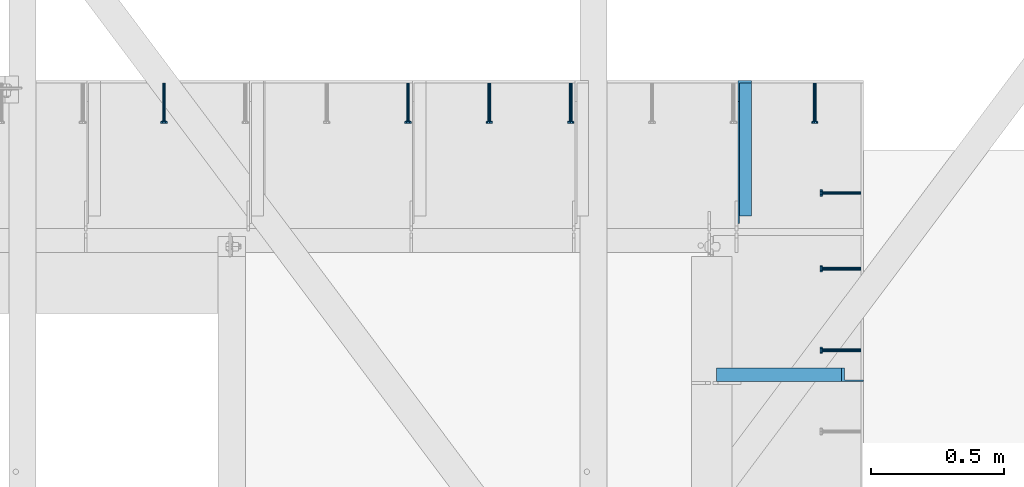
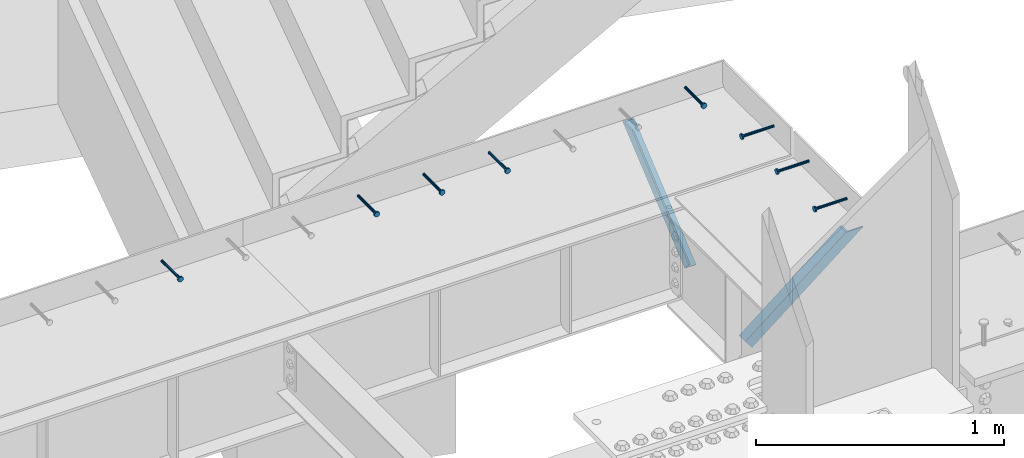
# One storey, part 1363 of 1763: 8 beams, 2 members, 10 elements without a shape of their own.
"""IFC2X3 building model written with IfcOpenShell, lengths in millimetres."""

from ifc_helpers import new_model, si_unit, frame, origin_with_axes, place, context, subcontext, project, spatial, faceted_brep, material, type_object, element, aggregate, save


model = new_model("IFC2X3")

# Units and contexts
model_context = context("Model", 3, precision=1e-05, world=origin_with_axes())
body_context = subcontext(model_context, "Body", "Model", "MODEL_VIEW")
ifc_project = project(units=[si_unit("LENGTHUNIT", "METRE", prefix="MILLI"), si_unit("AREAUNIT", "SQUARE_METRE"), si_unit("VOLUMEUNIT", "CUBIC_METRE"), si_unit("MASSUNIT", "GRAM", prefix="KILO"), si_unit("TIMEUNIT", "SECOND"), si_unit("PLANEANGLEUNIT", "RADIAN"), si_unit("SOLIDANGLEUNIT", "STERADIAN"), si_unit("THERMODYNAMICTEMPERATUREUNIT", "DEGREE_CELSIUS"), si_unit("LUMINOUSINTENSITYUNIT", "LUMEN")], contexts=[model_context])

# Site, building, storey
site_placement = place(None, origin_with_axes())
site = spatial("IfcSite", under=ifc_project, at=site_placement, CompositionType="ELEMENT")
building_placement = place(site_placement, origin_with_axes())
building = spatial("IfcBuilding", under=site, at=building_placement, Name="Undefined", CompositionType="ELEMENT")
storey_placement = place(building_placement, origin_with_axes())
storey = spatial("IfcBuildingStorey", under=building, at=storey_placement, Name="Undefined", CompositionType="ELEMENT", Elevation=0.0)

# Assembly, beam
assembly_1_placement = place(storey_placement, origin_with_axes())
assembly_1 = element("IfcElementAssembly", 1, at=assembly_1_placement, inside=storey, Name="HEADED STUD ANCHOR", AssemblyPlace="NOTDEFINED", PredefinedType="RIGID_FRAME")
ifc_material_1 = material(Name="STEEL/A108")
beam_type = type_object("IfcBeamType", PredefinedType="NOTDEFINED")
beam_1_placement = place(assembly_1_placement, frame((-34391.0368708663, 53201.8884999161, 5264.15), z_axis=(0.0, 0.0, 1.0), x_axis=(-1.0, 0.0, 0.0)))
beam_1 = element("IfcBeam", 2, at=beam_1_placement, type_object=beam_type, material=ifc_material_1, Name="HEADED STUD ANCHOR", context=body_context, shape_type="Brep", body=[
    faceted_brep([(0.0, -3.1800000667572, 5.5), (0.0, -5.5, 3.1800000667572), (141.732000000002, -5.5, 3.1800000667572), (141.732000000002, -3.1800000667572, 5.5), (0.0, -6.34999999999491, 1.45519152283669e-11), (141.732000000002, -6.34999990463257, 0.0), (0.0, -5.5, -3.1800000667572), (141.732000000002, -5.5, -3.1800000667572), (0.0, -3.1800000667572, -5.5), (141.732000000002, -3.1800000667572, -5.5), (0.0, 0.0, -6.34999990463257), (141.732000000002, 0.0, -6.34999990463257), (0.0, 3.1800000667572, -5.5), (141.732000000002, 3.1800000667572, -5.5), (0.0, 5.5, -3.1800000667572), (141.732000000002, 5.5, -3.1800000667572), (0.0, 6.34999999999491, -2.91038304567337e-11), (141.732000000002, 6.34999990463257, 0.0), (0.0, 5.5, 3.1800000667572), (141.732000000002, 5.5, 3.1800000667572), (0.0, 3.1800000667572, 5.5), (141.732000000002, 3.1800000667572, 5.5), (0.0, 0.0, 6.34999990463257), (141.732000000002, 0.0, 6.34999990463257), (144.780000000001, -10.9899997711182, 6.34999990463257), (144.780000000001, -6.34000015258789, 10.9899997711182), (144.780000000001, -12.6999998092651, 0.0), (144.780000000001, -10.9899997711182, -6.34999990463257), (144.780000000001, -6.34000015258789, -10.9899997711182), (144.780000000001, 0.0, -12.6899995803833), (144.780000000001, 6.34000015258789, -10.9899997711182), (144.780000000001, 10.9899997711182, -6.34999990463257), (144.780000000001, 12.6999998092651, 0.0), (144.780000000001, 10.9899997711182, 6.34999990463257), (144.780000000001, 6.34000015258789, 10.9899997711182), (144.780000000001, 0.0, 12.6899995803833), (152.400000000001, -10.9899997711182, 6.34999990463257), (152.400000000001, -6.34000015258789, 10.9899997711182), (152.400000000001, -12.6999998092651, 0.0), (152.400000000001, -10.9899997711182, -6.34999990463257), (152.400000000001, -6.34000015258789, -10.9899997711182), (152.400000000001, 0.0, -12.6899995803833), (152.400000000001, 6.34000015258789, -10.9899997711182), (152.400000000001, 10.9899997711182, -6.34999990463257), (152.400000000001, 12.6999998092651, 0.0), (152.400000000001, 10.9899997711182, 6.34999990463257), (152.400000000001, 6.34000015258789, 10.9899997711182), (152.400000000001, 0.0, 12.6899995803833)], [[[0, 1, 2, 3]], [[1, 4, 5, 2]], [[4, 6, 7, 5]], [[6, 8, 9, 7]], [[8, 10, 11, 9]], [[10, 12, 13, 11]], [[12, 14, 15, 13]], [[14, 16, 17, 15]], [[16, 18, 19, 17]], [[18, 20, 21, 19]], [[20, 22, 23, 21]], [[22, 0, 3, 23]], [[22, 20, 18, 16, 14, 12, 10, 8, 6, 4, 1, 0]], [[3, 2, 24, 25]], [[2, 5, 26, 24]], [[5, 7, 27, 26]], [[7, 9, 28, 27]], [[9, 11, 29, 28]], [[11, 13, 30, 29]], [[13, 15, 31, 30]], [[15, 17, 32, 31]], [[17, 19, 33, 32]], [[19, 21, 34, 33]], [[21, 23, 35, 34]], [[23, 3, 25, 35]], [[25, 24, 36, 37]], [[24, 26, 38, 36]], [[26, 27, 39, 38]], [[27, 28, 40, 39]], [[28, 29, 41, 40]], [[29, 30, 42, 41]], [[30, 31, 43, 42]], [[31, 32, 44, 43]], [[32, 33, 45, 44]], [[33, 34, 46, 45]], [[34, 35, 47, 46]], [[35, 25, 37, 47]], [[38, 39, 40, 41, 42, 43, 44, 45, 46, 47, 37, 36]]]),
])
aggregate(assembly_1, [beam_1])

assembly_2_placement = place(storey_placement, origin_with_axes())
assembly_2 = element("IfcElementAssembly", 3, at=assembly_2_placement, inside=storey, Name="HEADED STUD ANCHOR", AssemblyPlace="NOTDEFINED", PredefinedType="RIGID_FRAME")
beam_2_placement = place(assembly_2_placement, frame((-34391.0368708663, 53506.6884999161, 5264.15), z_axis=(0.0, 0.0, 1.0), x_axis=(-1.0, 0.0, 0.0)))
beam_2 = element("IfcBeam", 4, at=beam_2_placement, type_object=beam_type, material=ifc_material_1, Name="HEADED STUD ANCHOR", context=body_context, shape_type="Brep", body=[
    faceted_brep([(0.0, -3.1800000667572, 5.5), (0.0, -5.5, 3.1800000667572), (141.732000000002, -5.5, 3.1800000667572), (141.732000000002, -3.1800000667572, 5.5), (0.0, -6.34999999999491, 1.45519152283669e-11), (141.732000000002, -6.34999990463257, 0.0), (0.0, -5.5, -3.1800000667572), (141.732000000002, -5.5, -3.1800000667572), (0.0, -3.1800000667572, -5.5), (141.732000000002, -3.1800000667572, -5.5), (0.0, 0.0, -6.34999990463257), (141.732000000002, 0.0, -6.34999990463257), (0.0, 3.1800000667572, -5.5), (141.732000000002, 3.1800000667572, -5.5), (0.0, 5.5, -3.1800000667572), (141.732000000002, 5.5, -3.1800000667572), (0.0, 6.34999999999491, -2.91038304567337e-11), (141.732000000002, 6.34999990463257, 0.0), (0.0, 5.5, 3.1800000667572), (141.732000000002, 5.5, 3.1800000667572), (0.0, 3.1800000667572, 5.5), (141.732000000002, 3.1800000667572, 5.5), (0.0, 0.0, 6.34999990463257), (141.732000000002, 0.0, 6.34999990463257), (144.780000000001, -10.9899997711182, 6.34999990463257), (144.780000000001, -6.34000015258789, 10.9899997711182), (144.780000000001, -12.6999998092651, 0.0), (144.780000000001, -10.9899997711182, -6.34999990463257), (144.780000000001, -6.34000015258789, -10.9899997711182), (144.780000000001, 0.0, -12.6899995803833), (144.780000000001, 6.34000015258789, -10.9899997711182), (144.780000000001, 10.9899997711182, -6.34999990463257), (144.780000000001, 12.6999998092651, 0.0), (144.780000000001, 10.9899997711182, 6.34999990463257), (144.780000000001, 6.34000015258789, 10.9899997711182), (144.780000000001, 0.0, 12.6899995803833), (152.400000000001, -10.9899997711182, 6.34999990463257), (152.400000000001, -6.34000015258789, 10.9899997711182), (152.400000000001, -12.6999998092651, 0.0), (152.400000000001, -10.9899997711182, -6.34999990463257), (152.400000000001, -6.34000015258789, -10.9899997711182), (152.400000000001, 0.0, -12.6899995803833), (152.400000000001, 6.34000015258789, -10.9899997711182), (152.400000000001, 10.9899997711182, -6.34999990463257), (152.400000000001, 12.6999998092651, 0.0), (152.400000000001, 10.9899997711182, 6.34999990463257), (152.400000000001, 6.34000015258789, 10.9899997711182), (152.400000000001, 0.0, 12.6899995803833)], [[[0, 1, 2, 3]], [[1, 4, 5, 2]], [[4, 6, 7, 5]], [[6, 8, 9, 7]], [[8, 10, 11, 9]], [[10, 12, 13, 11]], [[12, 14, 15, 13]], [[14, 16, 17, 15]], [[16, 18, 19, 17]], [[18, 20, 21, 19]], [[20, 22, 23, 21]], [[22, 0, 3, 23]], [[22, 20, 18, 16, 14, 12, 10, 8, 6, 4, 1, 0]], [[3, 2, 24, 25]], [[2, 5, 26, 24]], [[5, 7, 27, 26]], [[7, 9, 28, 27]], [[9, 11, 29, 28]], [[11, 13, 30, 29]], [[13, 15, 31, 30]], [[15, 17, 32, 31]], [[17, 19, 33, 32]], [[19, 21, 34, 33]], [[21, 23, 35, 34]], [[23, 3, 25, 35]], [[25, 24, 36, 37]], [[24, 26, 38, 36]], [[26, 27, 39, 38]], [[27, 28, 40, 39]], [[28, 29, 41, 40]], [[29, 30, 42, 41]], [[30, 31, 43, 42]], [[31, 32, 44, 43]], [[32, 33, 45, 44]], [[33, 34, 46, 45]], [[34, 35, 47, 46]], [[35, 25, 37, 47]], [[38, 39, 40, 41, 42, 43, 44, 45, 46, 47, 37, 36]]]),
])
aggregate(assembly_2, [beam_2])

assembly_3_placement = place(storey_placement, origin_with_axes())
assembly_3 = element("IfcElementAssembly", 5, at=assembly_3_placement, inside=storey, Name="HEADED STUD ANCHOR", AssemblyPlace="NOTDEFINED", PredefinedType="RIGID_FRAME")
beam_3_placement = place(assembly_3_placement, frame((-34391.0453248389, 53790.8509999161, 5264.15), z_axis=(0.0, 0.0, 1.0), x_axis=(-1.0, 0.0, 0.0)))
beam_3 = element("IfcBeam", 6, at=beam_3_placement, type_object=beam_type, material=ifc_material_1, Name="HEADED STUD ANCHOR", context=body_context, shape_type="Brep", body=[
    faceted_brep([(0.0, -3.1800000667572, 5.5), (0.0, -5.5, 3.1800000667572), (141.732000000002, -5.5, 3.1800000667572), (141.732000000002, -3.1800000667572, 5.5), (0.0, -6.34999999999491, 1.45519152283669e-11), (141.732000000002, -6.34999990463257, 0.0), (0.0, -5.5, -3.1800000667572), (141.732000000002, -5.5, -3.1800000667572), (0.0, -3.1800000667572, -5.5), (141.732000000002, -3.1800000667572, -5.5), (0.0, 0.0, -6.34999990463257), (141.732000000002, 0.0, -6.34999990463257), (0.0, 3.1800000667572, -5.5), (141.732000000002, 3.1800000667572, -5.5), (0.0, 5.5, -3.1800000667572), (141.732000000002, 5.5, -3.1800000667572), (0.0, 6.34999999999491, -2.91038304567337e-11), (141.732000000002, 6.34999990463257, 0.0), (0.0, 5.5, 3.1800000667572), (141.732000000002, 5.5, 3.1800000667572), (0.0, 3.1800000667572, 5.5), (141.732000000002, 3.1800000667572, 5.5), (0.0, 0.0, 6.34999990463257), (141.732000000002, 0.0, 6.34999990463257), (144.780000000001, -10.9899997711182, 6.34999990463257), (144.780000000001, -6.34000015258789, 10.9899997711182), (144.780000000001, -12.6999998092651, 0.0), (144.780000000001, -10.9899997711182, -6.34999990463257), (144.780000000001, -6.34000015258789, -10.9899997711182), (144.780000000001, 0.0, -12.6899995803833), (144.780000000001, 6.34000015258789, -10.9899997711182), (144.780000000001, 10.9899997711182, -6.34999990463257), (144.780000000001, 12.6999998092651, 0.0), (144.780000000001, 10.9899997711182, 6.34999990463257), (144.780000000001, 6.34000015258789, 10.9899997711182), (144.780000000001, 0.0, 12.6899995803833), (152.400000000001, -10.9899997711182, 6.34999990463257), (152.400000000001, -6.34000015258789, 10.9899997711182), (152.400000000001, -12.6999998092651, 0.0), (152.400000000001, -10.9899997711182, -6.34999990463257), (152.400000000001, -6.34000015258789, -10.9899997711182), (152.400000000001, 0.0, -12.6899995803833), (152.400000000001, 6.34000015258789, -10.9899997711182), (152.400000000001, 10.9899997711182, -6.34999990463257), (152.400000000001, 12.6999998092651, 0.0), (152.400000000001, 10.9899997711182, 6.34999990463257), (152.400000000001, 6.34000015258789, 10.9899997711182), (152.400000000001, 0.0, 12.6899995803833)], [[[0, 1, 2, 3]], [[1, 4, 5, 2]], [[4, 6, 7, 5]], [[6, 8, 9, 7]], [[8, 10, 11, 9]], [[10, 12, 13, 11]], [[12, 14, 15, 13]], [[14, 16, 17, 15]], [[16, 18, 19, 17]], [[18, 20, 21, 19]], [[20, 22, 23, 21]], [[22, 0, 3, 23]], [[22, 20, 18, 16, 14, 12, 10, 8, 6, 4, 1, 0]], [[3, 2, 24, 25]], [[2, 5, 26, 24]], [[5, 7, 27, 26]], [[7, 9, 28, 27]], [[9, 11, 29, 28]], [[11, 13, 30, 29]], [[13, 15, 31, 30]], [[15, 17, 32, 31]], [[17, 19, 33, 32]], [[19, 21, 34, 33]], [[21, 23, 35, 34]], [[23, 3, 25, 35]], [[25, 24, 36, 37]], [[24, 26, 38, 36]], [[26, 27, 39, 38]], [[27, 28, 40, 39]], [[28, 29, 41, 40]], [[29, 30, 42, 41]], [[30, 31, 43, 42]], [[31, 32, 44, 43]], [[32, 33, 45, 44]], [[33, 34, 46, 45]], [[34, 35, 47, 46]], [[35, 25, 37, 47]], [[38, 39, 40, 41, 42, 43, 44, 45, 46, 47, 37, 36]]]),
])
aggregate(assembly_3, [beam_3])

assembly_4_placement = place(storey_placement, origin_with_axes())
assembly_4 = element("IfcElementAssembly", 7, at=assembly_4_placement, inside=storey, Name="HEADED STUD ANCHOR", AssemblyPlace="NOTDEFINED", PredefinedType="RIGID_FRAME")
beam_4_placement = place(assembly_4_placement, frame((-34564.0747736983, 54203.6, 5264.23140606069), z_axis=(0.0, 0.0, 1.0), x_axis=(0.0, -1.0, 0.0)))
beam_4 = element("IfcBeam", 8, at=beam_4_placement, type_object=beam_type, material=ifc_material_1, Name="HEADED STUD ANCHOR", context=body_context, shape_type="Brep", body=[
    faceted_brep([(0.0, -3.1800000667572, 5.5), (0.0, -5.5, 3.1800000667572), (141.732000000002, -5.5, 3.1800000667572), (141.732000000002, -3.1800000667572, 5.5), (0.0, -6.34999999999491, 1.45519152283669e-11), (141.732000000002, -6.34999990463257, 0.0), (0.0, -5.5, -3.1800000667572), (141.732000000002, -5.5, -3.1800000667572), (0.0, -3.1800000667572, -5.5), (141.732000000002, -3.1800000667572, -5.5), (0.0, 0.0, -6.34999990463257), (141.732000000002, 0.0, -6.34999990463257), (0.0, 3.1800000667572, -5.5), (141.732000000002, 3.1800000667572, -5.5), (0.0, 5.5, -3.1800000667572), (141.732000000002, 5.5, -3.1800000667572), (0.0, 6.34999999999491, -2.91038304567337e-11), (141.732000000002, 6.34999990463257, 0.0), (0.0, 5.5, 3.1800000667572), (141.732000000002, 5.5, 3.1800000667572), (0.0, 3.1800000667572, 5.5), (141.732000000002, 3.1800000667572, 5.5), (0.0, 0.0, 6.34999990463257), (141.732000000002, 0.0, 6.34999990463257), (144.780000000001, -10.9899997711182, 6.34999990463257), (144.780000000001, -6.34000015258789, 10.9899997711182), (144.780000000001, -12.6999998092651, 0.0), (144.780000000001, -10.9899997711182, -6.34999990463257), (144.780000000001, -6.34000015258789, -10.9899997711182), (144.780000000001, 0.0, -12.6899995803833), (144.780000000001, 6.34000015258789, -10.9899997711182), (144.780000000001, 10.9899997711182, -6.34999990463257), (144.780000000001, 12.6999998092651, 0.0), (144.780000000001, 10.9899997711182, 6.34999990463257), (144.780000000001, 6.34000015258789, 10.9899997711182), (144.780000000001, 0.0, 12.6899995803833), (152.400000000001, -10.9899997711182, 6.34999990463257), (152.400000000001, -6.34000015258789, 10.9899997711182), (152.400000000001, -12.6999998092651, 0.0), (152.400000000001, -10.9899997711182, -6.34999990463257), (152.400000000001, -6.34000015258789, -10.9899997711182), (152.400000000001, 0.0, -12.6899995803833), (152.400000000001, 6.34000015258789, -10.9899997711182), (152.400000000001, 10.9899997711182, -6.34999990463257), (152.400000000001, 12.6999998092651, 0.0), (152.400000000001, 10.9899997711182, 6.34999990463257), (152.400000000001, 6.34000015258789, 10.9899997711182), (152.400000000001, 0.0, 12.6899995803833)], [[[0, 1, 2, 3]], [[1, 4, 5, 2]], [[4, 6, 7, 5]], [[6, 8, 9, 7]], [[8, 10, 11, 9]], [[10, 12, 13, 11]], [[12, 14, 15, 13]], [[14, 16, 17, 15]], [[16, 18, 19, 17]], [[18, 20, 21, 19]], [[20, 22, 23, 21]], [[22, 0, 3, 23]], [[22, 20, 18, 16, 14, 12, 10, 8, 6, 4, 1, 0]], [[3, 2, 24, 25]], [[2, 5, 26, 24]], [[5, 7, 27, 26]], [[7, 9, 28, 27]], [[9, 11, 29, 28]], [[11, 13, 30, 29]], [[13, 15, 31, 30]], [[15, 17, 32, 31]], [[17, 19, 33, 32]], [[19, 21, 34, 33]], [[21, 23, 35, 34]], [[23, 3, 25, 35]], [[25, 24, 36, 37]], [[24, 26, 38, 36]], [[26, 27, 39, 38]], [[27, 28, 40, 39]], [[28, 29, 41, 40]], [[29, 30, 42, 41]], [[30, 31, 43, 42]], [[31, 32, 44, 43]], [[32, 33, 45, 44]], [[33, 34, 46, 45]], [[34, 35, 47, 46]], [[35, 25, 37, 47]], [[38, 39, 40, 41, 42, 43, 44, 45, 46, 47, 37, 36]]]),
])
aggregate(assembly_4, [beam_4])

assembly_5_placement = place(storey_placement, origin_with_axes())
assembly_5 = element("IfcElementAssembly", 9, at=assembly_5_placement, inside=storey, Name="HEADED STUD ANCHOR", AssemblyPlace="NOTDEFINED", PredefinedType="RIGID_FRAME")
beam_5_placement = place(assembly_5_placement, frame((-35478.4747736983, 54203.6, 5264.23140606069), z_axis=(0.0, 0.0, 1.0), x_axis=(0.0, -1.0, 0.0)))
beam_5 = element("IfcBeam", 10, at=beam_5_placement, type_object=beam_type, material=ifc_material_1, Name="HEADED STUD ANCHOR", context=body_context, shape_type="Brep", body=[
    faceted_brep([(0.0, -3.1800000667572, 5.5), (0.0, -5.5, 3.1800000667572), (141.732000000002, -5.5, 3.1800000667572), (141.732000000002, -3.1800000667572, 5.5), (0.0, -6.34999999999491, 1.45519152283669e-11), (141.732000000002, -6.34999990463257, 0.0), (0.0, -5.5, -3.1800000667572), (141.732000000002, -5.5, -3.1800000667572), (0.0, -3.1800000667572, -5.5), (141.732000000002, -3.1800000667572, -5.5), (0.0, 0.0, -6.34999990463257), (141.732000000002, 0.0, -6.34999990463257), (0.0, 3.1800000667572, -5.5), (141.732000000002, 3.1800000667572, -5.5), (0.0, 5.5, -3.1800000667572), (141.732000000002, 5.5, -3.1800000667572), (0.0, 6.34999999999491, -2.91038304567337e-11), (141.732000000002, 6.34999990463257, 0.0), (0.0, 5.5, 3.1800000667572), (141.732000000002, 5.5, 3.1800000667572), (0.0, 3.1800000667572, 5.5), (141.732000000002, 3.1800000667572, 5.5), (0.0, 0.0, 6.34999990463257), (141.732000000002, 0.0, 6.34999990463257), (144.780000000001, -10.9899997711182, 6.34999990463257), (144.780000000001, -6.34000015258789, 10.9899997711182), (144.780000000001, -12.6999998092651, 0.0), (144.780000000001, -10.9899997711182, -6.34999990463257), (144.780000000001, -6.34000015258789, -10.9899997711182), (144.780000000001, 0.0, -12.6899995803833), (144.780000000001, 6.34000015258789, -10.9899997711182), (144.780000000001, 10.9899997711182, -6.34999990463257), (144.780000000001, 12.6999998092651, 0.0), (144.780000000001, 10.9899997711182, 6.34999990463257), (144.780000000001, 6.34000015258789, 10.9899997711182), (144.780000000001, 0.0, 12.6899995803833), (152.400000000001, -10.9899997711182, 6.34999990463257), (152.400000000001, -6.34000015258789, 10.9899997711182), (152.400000000001, -12.6999998092651, 0.0), (152.400000000001, -10.9899997711182, -6.34999990463257), (152.400000000001, -6.34000015258789, -10.9899997711182), (152.400000000001, 0.0, -12.6899995803833), (152.400000000001, 6.34000015258789, -10.9899997711182), (152.400000000001, 10.9899997711182, -6.34999990463257), (152.400000000001, 12.6999998092651, 0.0), (152.400000000001, 10.9899997711182, 6.34999990463257), (152.400000000001, 6.34000015258789, 10.9899997711182), (152.400000000001, 0.0, 12.6899995803833)], [[[0, 1, 2, 3]], [[1, 4, 5, 2]], [[4, 6, 7, 5]], [[6, 8, 9, 7]], [[8, 10, 11, 9]], [[10, 12, 13, 11]], [[12, 14, 15, 13]], [[14, 16, 17, 15]], [[16, 18, 19, 17]], [[18, 20, 21, 19]], [[20, 22, 23, 21]], [[22, 0, 3, 23]], [[22, 20, 18, 16, 14, 12, 10, 8, 6, 4, 1, 0]], [[3, 2, 24, 25]], [[2, 5, 26, 24]], [[5, 7, 27, 26]], [[7, 9, 28, 27]], [[9, 11, 29, 28]], [[11, 13, 30, 29]], [[13, 15, 31, 30]], [[15, 17, 32, 31]], [[17, 19, 33, 32]], [[19, 21, 34, 33]], [[21, 23, 35, 34]], [[23, 3, 25, 35]], [[25, 24, 36, 37]], [[24, 26, 38, 36]], [[26, 27, 39, 38]], [[27, 28, 40, 39]], [[28, 29, 41, 40]], [[29, 30, 42, 41]], [[30, 31, 43, 42]], [[31, 32, 44, 43]], [[32, 33, 45, 44]], [[33, 34, 46, 45]], [[34, 35, 47, 46]], [[35, 25, 37, 47]], [[38, 39, 40, 41, 42, 43, 44, 45, 46, 47, 37, 36]]]),
])
aggregate(assembly_5, [beam_5])

assembly_6_placement = place(storey_placement, origin_with_axes())
assembly_6 = element("IfcElementAssembly", 11, at=assembly_6_placement, inside=storey, Name="HEADED STUD ANCHOR", AssemblyPlace="NOTDEFINED", PredefinedType="RIGID_FRAME")
beam_6_placement = place(assembly_6_placement, frame((-35783.2747736983, 54203.6, 5264.23140606069), z_axis=(0.0, 0.0, 1.0), x_axis=(0.0, -1.0, 0.0)))
beam_6 = element("IfcBeam", 12, at=beam_6_placement, type_object=beam_type, material=ifc_material_1, Name="HEADED STUD ANCHOR", context=body_context, shape_type="Brep", body=[
    faceted_brep([(0.0, -3.1800000667572, 5.5), (0.0, -5.5, 3.1800000667572), (141.732000000002, -5.5, 3.1800000667572), (141.732000000002, -3.1800000667572, 5.5), (0.0, -6.34999999999491, 1.45519152283669e-11), (141.732000000002, -6.34999990463257, 0.0), (0.0, -5.5, -3.1800000667572), (141.732000000002, -5.5, -3.1800000667572), (0.0, -3.1800000667572, -5.5), (141.732000000002, -3.1800000667572, -5.5), (0.0, 0.0, -6.34999990463257), (141.732000000002, 0.0, -6.34999990463257), (0.0, 3.1800000667572, -5.5), (141.732000000002, 3.1800000667572, -5.5), (0.0, 5.5, -3.1800000667572), (141.732000000002, 5.5, -3.1800000667572), (0.0, 6.34999999999491, -2.91038304567337e-11), (141.732000000002, 6.34999990463257, 0.0), (0.0, 5.5, 3.1800000667572), (141.732000000002, 5.5, 3.1800000667572), (0.0, 3.1800000667572, 5.5), (141.732000000002, 3.1800000667572, 5.5), (0.0, 0.0, 6.34999990463257), (141.732000000002, 0.0, 6.34999990463257), (144.780000000001, -10.9899997711182, 6.34999990463257), (144.780000000001, -6.34000015258789, 10.9899997711182), (144.780000000001, -12.6999998092651, 0.0), (144.780000000001, -10.9899997711182, -6.34999990463257), (144.780000000001, -6.34000015258789, -10.9899997711182), (144.780000000001, 0.0, -12.6899995803833), (144.780000000001, 6.34000015258789, -10.9899997711182), (144.780000000001, 10.9899997711182, -6.34999990463257), (144.780000000001, 12.6999998092651, 0.0), (144.780000000001, 10.9899997711182, 6.34999990463257), (144.780000000001, 6.34000015258789, 10.9899997711182), (144.780000000001, 0.0, 12.6899995803833), (152.400000000001, -10.9899997711182, 6.34999990463257), (152.400000000001, -6.34000015258789, 10.9899997711182), (152.400000000001, -12.6999998092651, 0.0), (152.400000000001, -10.9899997711182, -6.34999990463257), (152.400000000001, -6.34000015258789, -10.9899997711182), (152.400000000001, 0.0, -12.6899995803833), (152.400000000001, 6.34000015258789, -10.9899997711182), (152.400000000001, 10.9899997711182, -6.34999990463257), (152.400000000001, 12.6999998092651, 0.0), (152.400000000001, 10.9899997711182, 6.34999990463257), (152.400000000001, 6.34000015258789, 10.9899997711182), (152.400000000001, 0.0, 12.6899995803833)], [[[0, 1, 2, 3]], [[1, 4, 5, 2]], [[4, 6, 7, 5]], [[6, 8, 9, 7]], [[8, 10, 11, 9]], [[10, 12, 13, 11]], [[12, 14, 15, 13]], [[14, 16, 17, 15]], [[16, 18, 19, 17]], [[18, 20, 21, 19]], [[20, 22, 23, 21]], [[22, 0, 3, 23]], [[22, 20, 18, 16, 14, 12, 10, 8, 6, 4, 1, 0]], [[3, 2, 24, 25]], [[2, 5, 26, 24]], [[5, 7, 27, 26]], [[7, 9, 28, 27]], [[9, 11, 29, 28]], [[11, 13, 30, 29]], [[13, 15, 31, 30]], [[15, 17, 32, 31]], [[17, 19, 33, 32]], [[19, 21, 34, 33]], [[21, 23, 35, 34]], [[23, 3, 25, 35]], [[25, 24, 36, 37]], [[24, 26, 38, 36]], [[26, 27, 39, 38]], [[27, 28, 40, 39]], [[28, 29, 41, 40]], [[29, 30, 42, 41]], [[30, 31, 43, 42]], [[31, 32, 44, 43]], [[32, 33, 45, 44]], [[33, 34, 46, 45]], [[34, 35, 47, 46]], [[35, 25, 37, 47]], [[38, 39, 40, 41, 42, 43, 44, 45, 46, 47, 37, 36]]]),
])
aggregate(assembly_6, [beam_6])

assembly_7_placement = place(storey_placement, origin_with_axes())
assembly_7 = element("IfcElementAssembly", 13, at=assembly_7_placement, inside=storey, Name="HEADED STUD ANCHOR", AssemblyPlace="NOTDEFINED", PredefinedType="RIGID_FRAME")
beam_7_placement = place(assembly_7_placement, frame((-36088.0747736983, 54203.6, 5264.23140606069), z_axis=(0.0, 0.0, 1.0), x_axis=(0.0, -1.0, 0.0)))
beam_7 = element("IfcBeam", 14, at=beam_7_placement, type_object=beam_type, material=ifc_material_1, Name="HEADED STUD ANCHOR", context=body_context, shape_type="Brep", body=[
    faceted_brep([(0.0, -3.1800000667572, 5.5), (0.0, -5.5, 3.1800000667572), (141.732000000002, -5.5, 3.1800000667572), (141.732000000002, -3.1800000667572, 5.5), (0.0, -6.34999999999491, 1.45519152283669e-11), (141.732000000002, -6.34999990463257, 0.0), (0.0, -5.5, -3.1800000667572), (141.732000000002, -5.5, -3.1800000667572), (0.0, -3.1800000667572, -5.5), (141.732000000002, -3.1800000667572, -5.5), (0.0, 0.0, -6.34999990463257), (141.732000000002, 0.0, -6.34999990463257), (0.0, 3.1800000667572, -5.5), (141.732000000002, 3.1800000667572, -5.5), (0.0, 5.5, -3.1800000667572), (141.732000000002, 5.5, -3.1800000667572), (0.0, 6.34999999999491, -2.91038304567337e-11), (141.732000000002, 6.34999990463257, 0.0), (0.0, 5.5, 3.1800000667572), (141.732000000002, 5.5, 3.1800000667572), (0.0, 3.1800000667572, 5.5), (141.732000000002, 3.1800000667572, 5.5), (0.0, 0.0, 6.34999990463257), (141.732000000002, 0.0, 6.34999990463257), (144.780000000001, -10.9899997711182, 6.34999990463257), (144.780000000001, -6.34000015258789, 10.9899997711182), (144.780000000001, -12.6999998092651, 0.0), (144.780000000001, -10.9899997711182, -6.34999990463257), (144.780000000001, -6.34000015258789, -10.9899997711182), (144.780000000001, 0.0, -12.6899995803833), (144.780000000001, 6.34000015258789, -10.9899997711182), (144.780000000001, 10.9899997711182, -6.34999990463257), (144.780000000001, 12.6999998092651, 0.0), (144.780000000001, 10.9899997711182, 6.34999990463257), (144.780000000001, 6.34000015258789, 10.9899997711182), (144.780000000001, 0.0, 12.6899995803833), (152.400000000001, -10.9899997711182, 6.34999990463257), (152.400000000001, -6.34000015258789, 10.9899997711182), (152.400000000001, -12.6999998092651, 0.0), (152.400000000001, -10.9899997711182, -6.34999990463257), (152.400000000001, -6.34000015258789, -10.9899997711182), (152.400000000001, 0.0, -12.6899995803833), (152.400000000001, 6.34000015258789, -10.9899997711182), (152.400000000001, 10.9899997711182, -6.34999990463257), (152.400000000001, 12.6999998092651, 0.0), (152.400000000001, 10.9899997711182, 6.34999990463257), (152.400000000001, 6.34000015258789, 10.9899997711182), (152.400000000001, 0.0, 12.6899995803833)], [[[0, 1, 2, 3]], [[1, 4, 5, 2]], [[4, 6, 7, 5]], [[6, 8, 9, 7]], [[8, 10, 11, 9]], [[10, 12, 13, 11]], [[12, 14, 15, 13]], [[14, 16, 17, 15]], [[16, 18, 19, 17]], [[18, 20, 21, 19]], [[20, 22, 23, 21]], [[22, 0, 3, 23]], [[22, 20, 18, 16, 14, 12, 10, 8, 6, 4, 1, 0]], [[3, 2, 24, 25]], [[2, 5, 26, 24]], [[5, 7, 27, 26]], [[7, 9, 28, 27]], [[9, 11, 29, 28]], [[11, 13, 30, 29]], [[13, 15, 31, 30]], [[15, 17, 32, 31]], [[17, 19, 33, 32]], [[19, 21, 34, 33]], [[21, 23, 35, 34]], [[23, 3, 25, 35]], [[25, 24, 36, 37]], [[24, 26, 38, 36]], [[26, 27, 39, 38]], [[27, 28, 40, 39]], [[28, 29, 41, 40]], [[29, 30, 42, 41]], [[30, 31, 43, 42]], [[31, 32, 44, 43]], [[32, 33, 45, 44]], [[33, 34, 46, 45]], [[34, 35, 47, 46]], [[35, 25, 37, 47]], [[38, 39, 40, 41, 42, 43, 44, 45, 46, 47, 37, 36]]]),
])
aggregate(assembly_7, [beam_7])

assembly_8_placement = place(storey_placement, origin_with_axes())
assembly_8 = element("IfcElementAssembly", 15, at=assembly_8_placement, inside=storey, Name="HEADED STUD ANCHOR", AssemblyPlace="NOTDEFINED", PredefinedType="RIGID_FRAME")
beam_8_placement = place(assembly_8_placement, frame((-37002.4747736983, 54203.6, 5264.23140606069), z_axis=(0.0, 0.0, 1.0), x_axis=(0.0, -1.0, 0.0)))
beam_8 = element("IfcBeam", 16, at=beam_8_placement, type_object=beam_type, material=ifc_material_1, Name="HEADED STUD ANCHOR", context=body_context, shape_type="Brep", body=[
    faceted_brep([(0.0, -3.1800000667572, 5.5), (0.0, -5.5, 3.1800000667572), (141.732000000002, -5.5, 3.1800000667572), (141.732000000002, -3.1800000667572, 5.5), (0.0, -6.34999999999491, 1.45519152283669e-11), (141.732000000002, -6.34999990463257, 0.0), (0.0, -5.5, -3.1800000667572), (141.732000000002, -5.5, -3.1800000667572), (0.0, -3.1800000667572, -5.5), (141.732000000002, -3.1800000667572, -5.5), (0.0, 0.0, -6.34999990463257), (141.732000000002, 0.0, -6.34999990463257), (0.0, 3.1800000667572, -5.5), (141.732000000002, 3.1800000667572, -5.5), (0.0, 5.5, -3.1800000667572), (141.732000000002, 5.5, -3.1800000667572), (0.0, 6.34999999999491, -2.91038304567337e-11), (141.732000000002, 6.34999990463257, 0.0), (0.0, 5.5, 3.1800000667572), (141.732000000002, 5.5, 3.1800000667572), (0.0, 3.1800000667572, 5.5), (141.732000000002, 3.1800000667572, 5.5), (0.0, 0.0, 6.34999990463257), (141.732000000002, 0.0, 6.34999990463257), (144.780000000001, -10.9899997711182, 6.34999990463257), (144.780000000001, -6.34000015258789, 10.9899997711182), (144.780000000001, -12.6999998092651, 0.0), (144.780000000001, -10.9899997711182, -6.34999990463257), (144.780000000001, -6.34000015258789, -10.9899997711182), (144.780000000001, 0.0, -12.6899995803833), (144.780000000001, 6.34000015258789, -10.9899997711182), (144.780000000001, 10.9899997711182, -6.34999990463257), (144.780000000001, 12.6999998092651, 0.0), (144.780000000001, 10.9899997711182, 6.34999990463257), (144.780000000001, 6.34000015258789, 10.9899997711182), (144.780000000001, 0.0, 12.6899995803833), (152.400000000001, -10.9899997711182, 6.34999990463257), (152.400000000001, -6.34000015258789, 10.9899997711182), (152.400000000001, -12.6999998092651, 0.0), (152.400000000001, -10.9899997711182, -6.34999990463257), (152.400000000001, -6.34000015258789, -10.9899997711182), (152.400000000001, 0.0, -12.6899995803833), (152.400000000001, 6.34000015258789, -10.9899997711182), (152.400000000001, 10.9899997711182, -6.34999990463257), (152.400000000001, 12.6999998092651, 0.0), (152.400000000001, 10.9899997711182, 6.34999990463257), (152.400000000001, 6.34000015258789, 10.9899997711182), (152.400000000001, 0.0, 12.6899995803833)], [[[0, 1, 2, 3]], [[1, 4, 5, 2]], [[4, 6, 7, 5]], [[6, 8, 9, 7]], [[8, 10, 11, 9]], [[10, 12, 13, 11]], [[12, 14, 15, 13]], [[14, 16, 17, 15]], [[16, 18, 19, 17]], [[18, 20, 21, 19]], [[20, 22, 23, 21]], [[22, 0, 3, 23]], [[22, 20, 18, 16, 14, 12, 10, 8, 6, 4, 1, 0]], [[3, 2, 24, 25]], [[2, 5, 26, 24]], [[5, 7, 27, 26]], [[7, 9, 28, 27]], [[9, 11, 29, 28]], [[11, 13, 30, 29]], [[13, 15, 31, 30]], [[15, 17, 32, 31]], [[17, 19, 33, 32]], [[19, 21, 34, 33]], [[21, 23, 35, 34]], [[23, 3, 25, 35]], [[25, 24, 36, 37]], [[24, 26, 38, 36]], [[26, 27, 39, 38]], [[27, 28, 40, 39]], [[28, 29, 41, 40]], [[29, 30, 42, 41]], [[30, 31, 43, 42]], [[31, 32, 44, 43]], [[32, 33, 45, 44]], [[33, 34, 46, 45]], [[34, 35, 47, 46]], [[35, 25, 37, 47]], [[38, 39, 40, 41, 42, 43, 44, 45, 46, 47, 37, 36]]]),
])
aggregate(assembly_8, [beam_8])

# Assembly, member
assembly_9_placement = place(storey_placement, origin_with_axes())
assembly_9 = element("IfcElementAssembly", 17, at=assembly_9_placement, inside=storey, Name="BEAM", AssemblyPlace="NOTDEFINED", PredefinedType="RIGID_FRAME")
ifc_material_2 = material(Name="STEEL/A36")
member_type = type_object("IfcMemberType", Name="L2X2X1/4", PredefinedType="NOTDEFINED")
member_1_placement = place(assembly_9_placement, frame((-34827.0044734054, 53692.8752601513, 4792.34833807684), z_axis=(0.0, -0.641507205139845, 0.767117009167223), x_axis=(0.0, 0.767117009167224, 0.641507205139844)))
member_1 = element("IfcMember", 18, at=member_1_placement, type_object=member_type, material=ifc_material_2, Name="ANGLE", ObjectType="L2X2X1/4", context=body_context, shape_type="Brep", body=[
    faceted_brep([(-1.45519152283669e-11, 25.4000000000015, -25.3999999999869), (1.45519152283669e-11, 25.4000000000015, 25.3999999999796), (596.200457969971, 25.4000000000015, 25.3999999984771), (656.947310752032, 25.4000000000015, -25.4000000016313), (1.45519152283669e-11, 19.0499999999993, 25.3999999999796), (596.200457969971, 19.0500000000029, 25.3999999984771), (-7.27595761418343e-12, 19.0499999999993, -19.0499999999956), (649.35395415427, 19.0500000000029, -19.0500000016218), (-7.27595761418343e-12, -25.4000000000015, -19.0499999999956), (649.35395415427, -25.4000000000015, -19.0500000016218), (-1.45519152283669e-11, -25.4000000000015, -25.3999999999869), (656.947310752032, -25.4000000000015, -25.4000000016313)], [[[0, 1, 2, 3]], [[1, 4, 5, 2]], [[4, 6, 7, 5]], [[6, 8, 9, 7]], [[8, 10, 11, 9]], [[10, 0, 3, 11]], [[5, 7, 9, 11, 3, 2]], [[10, 8, 6, 4, 1, 0]]]),
])
aggregate(assembly_9, [member_1])

assembly_10_placement = place(storey_placement, origin_with_axes())
assembly_10 = element("IfcElementAssembly", 19, at=assembly_10_placement, inside=storey, Name="BEAM", AssemblyPlace="NOTDEFINED", PredefinedType="RIGID_FRAME")
member_2_placement = place(assembly_10_placement, frame((-34397.366028907, 53109.01875, 5214.14487893408), z_axis=(0.0, 1.0, 0.0), x_axis=(-0.781294446472435, 0.0, -0.624162629377418)))
member_2 = element("IfcMember", 20, at=member_2_placement, type_object=member_type, material=ifc_material_2, Name="ANGLE", ObjectType="L2X2X1/4", context=body_context, shape_type="Brep", body=[
    faceted_brep([(63.5888084396283, 25.4000000000851, -25.4000000000015), (63.5888084396283, 25.4000000000851, 25.4000000000015), (663.914585009134, 25.4000000008928, 25.4000000000015), (663.914585009134, 25.4000000008928, -25.4000000000015), (55.6402073834033, 19.0500000000684, 25.4000000000015), (663.914585009134, 19.0500000008979, 25.4000000000015), (55.6402073834033, 19.0500000000684, -19.0500000000029), (663.914585009134, 19.0500000008979, -19.0500000000029), (-7.27595761418343e-12, -25.4000000000015, -19.0499999999956), (663.914585009119, -25.3999999991029, -19.0500000000029), (-1.45519152283669e-11, -25.4000000000015, -25.3999999999869), (663.914585009119, -25.3999999991029, -25.4000000000015)], [[[0, 1, 2, 3]], [[1, 4, 5, 2]], [[4, 6, 7, 5]], [[6, 8, 9, 7]], [[8, 10, 11, 9]], [[10, 0, 3, 11]], [[5, 7, 9, 11, 3, 2]], [[10, 8, 6, 4, 1, 0]]]),
])
aggregate(assembly_10, [member_2])

save(model, "model.ifc")
